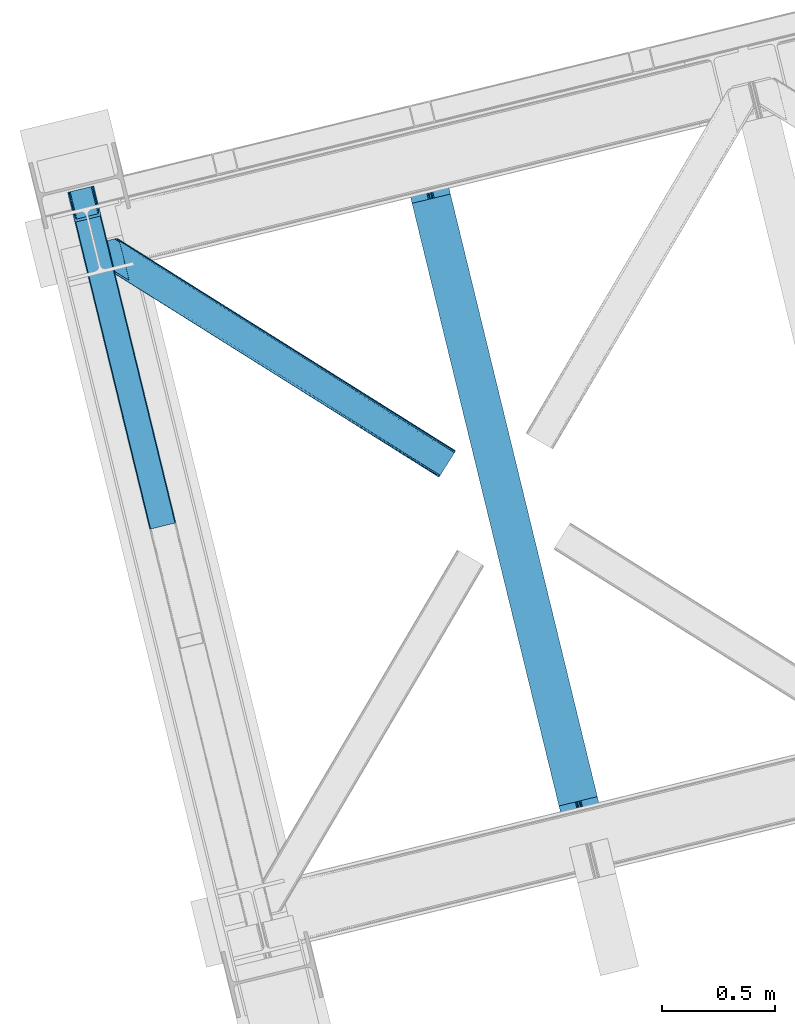
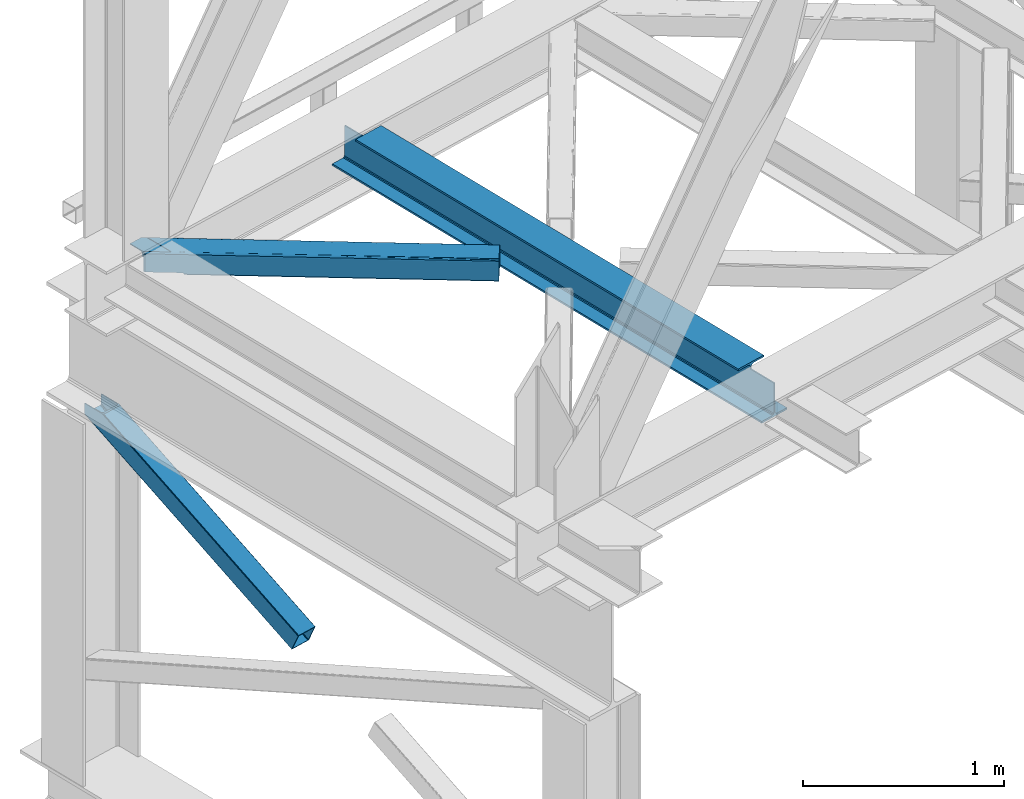
# One storey, part 25 of 92: 2 members, 1 beam.
"""IFC4 building model written with IfcOpenShell, lengths in millimetres."""

from ifc_helpers import new_model, entity, si_unit, converted_unit, derived_unit, direction, frame, origin, place, context, subcontext, project, spatial, triangles, polygons, material, type_object, element, save


model = new_model("IFC4")

# Units and contexts
model_context = context("Model", 3, precision=0.01, world=origin(), true_north=direction((6.12303176911189e-17, 1.0)))
plan_context = context("Plan", 3, precision=0.01, world=origin(), true_north=direction((6.12303176911189e-17, 1.0)))
body_context = subcontext(model_context, "Body", "Model", "MODEL_VIEW")
ifc_project = project(units=[si_unit("LENGTHUNIT", "METRE", prefix="MILLI"), si_unit("AREAUNIT", "SQUARE_METRE"), si_unit("VOLUMEUNIT", "CUBIC_METRE"), converted_unit("PLANEANGLEUNIT", "DEGREE", entity("IfcRatioMeasure", 0.0174532925199433), si_unit("PLANEANGLEUNIT", "RADIAN"), dimensions=[0, 0, 0, 0, 0, 0, 0]), si_unit("MASSUNIT", "GRAM", prefix="KILO"), derived_unit("MASSDENSITYUNIT", [(si_unit("MASSUNIT", "GRAM", prefix="KILO"), 1), (si_unit("LENGTHUNIT", "METRE"), -3)]), derived_unit("MOMENTOFINERTIAUNIT", [(si_unit("LENGTHUNIT", "METRE"), 4)]), si_unit("TIMEUNIT", "SECOND"), si_unit("FREQUENCYUNIT", "HERTZ"), si_unit("THERMODYNAMICTEMPERATUREUNIT", "DEGREE_CELSIUS"), derived_unit("THERMALTRANSMITTANCEUNIT", [(si_unit("MASSUNIT", "GRAM", prefix="KILO"), 1), (si_unit("THERMODYNAMICTEMPERATUREUNIT", "KELVIN"), -1), (si_unit("TIMEUNIT", "SECOND"), -3)]), derived_unit("VOLUMETRICFLOWRATEUNIT", [(si_unit("LENGTHUNIT", "METRE"), 3), (si_unit("TIMEUNIT", "SECOND"), -1)]), derived_unit("MASSFLOWRATEUNIT", [(si_unit("MASSUNIT", "GRAM", prefix="KILO"), 1), (si_unit("TIMEUNIT", "SECOND"), -1)]), derived_unit("ROTATIONALFREQUENCYUNIT", [(si_unit("TIMEUNIT", "SECOND"), -1)]), si_unit("ELECTRICCURRENTUNIT", "AMPERE"), si_unit("ELECTRICVOLTAGEUNIT", "VOLT"), si_unit("POWERUNIT", "WATT"), si_unit("FORCEUNIT", "NEWTON", prefix="KILO"), si_unit("ILLUMINANCEUNIT", "LUX"), si_unit("LUMINOUSFLUXUNIT", "LUMEN"), si_unit("LUMINOUSINTENSITYUNIT", "CANDELA"), derived_unit("USERDEFINED", [(si_unit("MASSUNIT", "GRAM", prefix="KILO"), -1), (si_unit("LENGTHUNIT", "METRE"), -2), (si_unit("TIMEUNIT", "SECOND"), 3), (si_unit("LUMINOUSFLUXUNIT", "LUMEN"), 1)]), derived_unit("LINEARVELOCITYUNIT", [(si_unit("LENGTHUNIT", "METRE"), 1), (si_unit("TIMEUNIT", "SECOND"), -1)]), si_unit("PRESSUREUNIT", "PASCAL"), derived_unit("USERDEFINED", [(si_unit("LENGTHUNIT", "METRE"), -2), (si_unit("MASSUNIT", "GRAM", prefix="KILO"), 1), (si_unit("TIMEUNIT", "SECOND"), -2)]), derived_unit("LINEARFORCEUNIT", [(si_unit("MASSUNIT", "GRAM", prefix="KILO"), 1), (si_unit("LENGTHUNIT", "METRE"), 1), (si_unit("TIMEUNIT", "SECOND"), -2), (si_unit("LENGTHUNIT", "METRE"), -1)]), derived_unit("PLANARFORCEUNIT", [(si_unit("MASSUNIT", "GRAM", prefix="KILO"), 1), (si_unit("LENGTHUNIT", "METRE"), 1), (si_unit("TIMEUNIT", "SECOND"), -2), (si_unit("LENGTHUNIT", "METRE"), -2)])], contexts=[model_context, plan_context])

# Site, building, storey
site_placement = place(None, origin())
site = spatial("IfcSite", under=ifc_project, at=site_placement, CompositionType="ELEMENT")
building_placement = place(site_placement, origin())
building = spatial("IfcBuilding", under=site, at=building_placement, CompositionType="ELEMENT")
storey_placement = place(building_placement, frame((0.0, 0.0, 15900.0)))
storey = spatial("IfcBuildingStorey", under=building, at=storey_placement, Name="05", CompositionType="ELEMENT", Elevation=15900.0)

# Beam
ifc_material = material(Name="Metal painted (White)")
beam_type = type_object("IfcBeamType", PredefinedType="BEAM")
beam_placement = place(storey_placement, frame((-59635.89, 3249.83, 3441.0)))
element("IfcBeam", 1, at=beam_placement, inside=storey, type_object=beam_type, material=ifc_material, ObjectType="Steel Beam", PredefinedType="BEAM", context=body_context, shape_type="Tessellation", body=[
    polygons([(900.98534618944, 41.4445662733097, 11.000000000004), (900.98534618944, 41.4445662733097, 2.16573425859679e-12), (170.021610174761, 3040.13999372697, 2.16573425859679e-12), (170.021610174761, 3040.13999372697, 11.000000000004), (834.919806235823, 25.3403919499672, 11.000000000004), (103.956070221144, 3024.03581940363, 11.000000000004), (828.971056214531, 23.8903211957396, 12.2179274798217), (98.0073201998513, 3022.5857486494, 12.2179274798217), (823.927949458422, 22.66101056892, 15.6862915010192), (92.9642134437427, 3021.35643802258, 15.6862915010192), (820.558253255246, 21.8396114687124, 20.8770650821657), (89.5945172405668, 3020.53503892237, 20.8770650821657), (819.37497330556, 21.5511744621211, 27.0000000000047), (88.4112372908809, 3020.24660191578, 27.0000000000047), (81.6103728838801, 3018.58881926485, 27.0000000000047), (81.6103728838888, 3018.58881926485, 203.000000000006), (88.4112372908809, 3020.24660191578, 203.000000000006), (0.0, 2998.69542745366, 2.16573425859679e-12), (0.0, 2998.69542745366, 10.9999999999997), (66.0655399536345, 3014.799601777, 11.000000000004), (72.014289974927, 3016.24967253123, 12.2179274798217), (77.057396731027, 3017.47898315805, 15.6862915010192), (80.4270929341942, 3018.30038225826, 20.8770650821657), (819.374973305543, 21.5511744621206, 203.000000000006), (812.574108898559, 19.8933918111892, 203.000000000006), (812.574108898559, 19.8933918111892, 27.0000000000047), (811.390828948873, 19.6049548045968, 20.8770650821657), (808.021132745698, 18.7835557043893, 15.6862915010192), (802.978025989589, 17.5542450775691, 12.2179274798217), (797.029275968296, 16.1041743233431, 11.000000000004), (730.963736014679, 0.0, 10.9999999999997), (730.963736014679, 0.0, 2.16573425859679e-12), (779.675212882757, 184.415062601692, 203.069791966819), (128.020401343512, 2857.75452019162, 203.000000000006), (128.24328213265, 2856.8401777572, 203.617301946336), (128.256196377177, 2856.7871977843, 217.000003693143), (779.530009633824, 185.010597404072, 217.000003676718), (779.530880241731, 185.007025963192, 204.00000679514), (772.964911718311, 182.385463974443, 203.006342981529), (772.742064056782, 183.299815969774, 203.617301946336), (772.729149812263, 183.352795942669, 217.000003693143), (121.455336555608, 2855.1293963229, 217.000003676718), (121.45446594771, 2855.13296776378, 204.00000679514), (121.310166358664, 2855.72494066435, 203.076120467494), (121.219536936511, 2856.09673754069, 203.000000000006), (780.713494357868, 185.298194377515, 223.122939328039), (784.082490766547, 186.122464201394, 228.313710402595), (789.125126170554, 187.353708426698, 231.782072735464), (795.073705041275, 188.80448128138, 232.999999602236), (861.13915590679, 204.909021065315, 232.999999283132), (861.137682570352, 204.915065042188, 243.999994005812), (691.116301666431, 163.469558245298, 243.999994827032), (691.117775002877, 163.463514268425, 233.000000104353), (757.183225868401, 179.568054052359, 232.999999785253), (763.132130996731, 181.017488520583, 231.782072861012), (768.175695503862, 182.244921343719, 228.313710479427), (771.546082413602, 183.063487001148, 223.12293937232), (120.271851831572, 2854.84179934945, 223.122939328039), (116.902855422893, 2854.01752952557, 228.313710402595), (111.860220018869, 2852.78628530027, 231.782072735464), (105.911641148165, 2851.33551244559, 232.999999602236), (39.8461902826505, 2835.23097266165, 232.999999283128), (39.8476636190794, 2835.22492868478, 243.999994005812), (209.869044523001, 2876.67043548167, 243.999994827032), (209.867571186572, 2876.67647945854, 233.000000104357), (143.80212032104, 2860.57193967461, 232.999999785253), (137.85321519271, 2859.12250520639, 231.782072861012), (132.809650685579, 2857.89507238325, 228.313710479427), (129.439263775838, 2857.07650672582, 223.12293937232)], [[[1, 2, 3, 4]], [[5, 1, 4, 6]], [[7, 5, 6, 8]], [[9, 7, 8, 10]], [[11, 9, 10, 12]], [[13, 11, 12, 14]], [[15, 16, 17, 14, 12, 10, 8, 6, 4, 3, 18, 19, 20, 21, 22, 23]], [[13, 24, 25, 26, 27, 28, 29, 30, 31, 32, 2, 1, 5, 7, 9, 11]], [[2, 32, 18, 3]], [[32, 31, 19, 18]], [[31, 30, 20, 19]], [[27, 26, 15, 23]], [[28, 27, 23, 22]], [[29, 28, 22, 21]], [[30, 29, 21, 20]], [[33, 24, 13, 14, 17, 34, 35, 36, 37, 38]], [[25, 39, 40, 41, 42, 43, 44, 16, 15, 26]], [[39, 25, 24, 33]], [[45, 34, 17, 16]], [[41, 40, 38, 37, 46, 47, 48, 49, 50, 51, 52, 53, 54, 55, 56, 57]], [[42, 58, 59, 60, 61, 62, 63, 64, 65, 66, 67, 68, 69, 36, 35, 43]], [[46, 37, 36, 69]], [[47, 46, 69, 68]], [[48, 47, 68, 67]], [[49, 48, 67, 66]], [[50, 49, 66, 65]], [[51, 50, 65, 64]], [[52, 51, 64, 63]], [[53, 52, 63, 62]], [[54, 53, 62, 61]], [[55, 54, 61, 60]], [[56, 55, 60, 59]], [[57, 56, 59, 58]], [[41, 57, 58, 42]]], closed=False),
])

# Members
member_type_1 = type_object("IfcMemberType", PredefinedType="BRACE")
member_1_placement = place(storey_placement, frame((-61123.58, 4641.45, 1850.35)))
element("IfcMember", 2, at=member_1_placement, inside=storey, type_object=member_type_1, ObjectType="Steel Vertical Brace", PredefinedType="BRACE", context=body_context, shape_type="Tessellation", body=[
    triangles([(109.78864746094, 1519.24680175781, 671.707836914062), (462.204345703125, 73.4905723571783, 0.0), (6.80423583984521, 1494.14368286133, 671.707836914062), (359.21993408203, 48.3871627807621, 0.0), (464.859997558597, 73.9117675781254, 0.48601684570167), (467.213342285155, 73.8434577941898, 1.86965332031104), (112.19315185547, 1519.83339385986, 672.832186889649), (468.910913085936, 73.2946540832527, 3.93929443359229), (114.59765625, 1520.41940460205, 673.956536865233), (469.687609863278, 72.3502349853516, 6.38100585937354), (115.592944335935, 1520.66183166504, 676.672650146484), (116.588232421876, 1520.90484008789, 679.387600708007), (353.104028320311, 43.9313301086431, 6.38100585937354), (0.0, 1492.48564453125, 679.387600708007), (0.99993896484375, 1492.7286529541, 676.672650146484), (353.359826660155, 45.128059387207, 3.93929443359229), (1.99522705077834, 1492.97108001709, 673.956536865233), (354.61091308594, 46.3954238891602, 1.86965332031104), (4.39973144531541, 1493.55709075928, 672.832186889649), (356.671252441403, 47.5395401000978, 0.48601684570167), (144.939990234372, 1404.59159088135, 741.646591186523), (116.588232421876, 1520.90484008789, 741.646591186523), (480.017211914063, 29.9807281494141, 102.993713378906), (28.3564086914048, 1376.17239532471, 741.646591186523), (0.0, 1492.48564453125, 741.646591186523), (363.428979492186, 1.5615325927738, 102.993713378906), (476.44998779297, 26.3725181579593, 108.888702392578), (144.465600585936, 1388.29607391357, 741.646591186523), (142.168066406251, 1386.40316619873, 741.646591186523), (473.896655273435, 25.5248954772951, 109.37471923828), (478.505676269531, 27.516634368897, 107.505065917969), (145.795751953126, 1392.41733398438, 741.646591186523), (479.761413574219, 28.7839988708502, 105.435424804688), (145.963183593747, 1398.13907775879, 741.646591186523), (39.1836547851563, 1361.29946594238, 741.646591186523), (370.912243652347, 0.421485900878906, 109.37471923828), (364.210327148438, 0.617113494873593, 105.435424804688), (30.4120971679658, 1369.97219238281, 741.646591186523), (365.90324707031, 0.0686004638673694, 107.505065917969), (33.1933227539048, 1364.96900939941, 741.646591186523), (368.256591796875, 0.0, 108.888702392578), (36.27685546875, 1361.92384643555, 741.646591186523), (138.061340332031, 1403.04052276611, 741.646591186523), (137.205578613284, 1415.21477966309, 741.646591186523), (111.728063964845, 1519.72061004639, 741.646591186523), (138.228771972659, 1408.76284790039, 741.646591186523), (136.731188964841, 1398.91926269531, 741.646591186523), (134.433654785156, 1397.02635498047, 741.646591186523), (35.1745971679702, 1377.96065826416, 741.646591186523), (32.3933715820313, 1382.96442260742, 741.646591186523), (30.333032226561, 1389.16346282959, 741.646591186523), (4.86016845703125, 1493.66987457275, 741.646591186523), (38.2534790039063, 1374.91491394043, 741.646591186523), (41.1649291992217, 1374.29111480713, 741.646591186523), (474.673352050784, 30.7952133178715, 98.4370147705085), (474.412902832031, 29.5981933593757, 100.87872619629), (473.161816406253, 28.3311195373535, 102.948367309571), (471.101477050783, 27.1867126464849, 104.330841064453), (468.552795410156, 26.3393806457525, 104.816857910155), (375.284069824222, 3.60414047241284, 104.816857910155), (372.62841796875, 3.18265457153393, 104.330841064453), (370.275073242185, 3.25154571533221, 102.948367309571), (368.577502441403, 3.79976806640661, 100.87872619629), (367.800805664061, 4.74418716430682, 98.4370147705085), (111.728063964845, 1519.72061004639, 684.873312377931), (465.315783691403, 69.1675804138185, 10.9377044677749), (4.86016845703125, 1493.66987457275, 684.873312377931), (358.447888183597, 43.1168449401857, 10.9377044677749), (462.84151611328, 70.660512542725, 6.42635192871239), (464.539086914061, 70.1122901916506, 8.49599304199364), (460.488171386722, 70.7294036865242, 5.04387817382667), (457.837170410159, 70.3079177856453, 4.557861328125), (359.954772949219, 45.5809387207037, 6.42635192871239), (362.015112304689, 46.7253456115723, 5.04387817382667), (358.70368652344, 44.3138648986824, 8.49599304199364), (364.563793945315, 47.5726776123047, 4.557861328125), (11.6597534179673, 1495.32733154297, 677.193548583986), (9.2552490234375, 1494.74132080078, 678.31789855957), (6.85074462890771, 1494.15531005859, 679.443411254884), (104.928479003909, 1518.06315307617, 677.193548583986), (107.332983398439, 1518.64916381836, 678.31789855957), (109.737487792969, 1519.23517456055, 679.443411254884), (5.85545654296584, 1493.91230163574, 682.158361816408), (110.732775878903, 1519.4781829834, 682.158361816408)], [[1, 2, 3], [4, 3, 2], [5, 2, 1], [6, 5, 7], [8, 6, 9], [10, 8, 11], [11, 12, 10], [9, 11, 8], [7, 9, 6], [1, 7, 5], [13, 14, 15], [16, 15, 17], [18, 17, 19], [20, 19, 3], [3, 4, 20], [19, 20, 18], [17, 18, 16], [15, 16, 13], [12, 21, 10], [21, 12, 22], [23, 10, 21], [24, 14, 13], [24, 25, 14], [13, 26, 24], [27, 28, 29], [29, 30, 27], [31, 32, 28], [28, 27, 31], [33, 34, 32], [32, 31, 33], [23, 21, 34], [34, 33, 23], [30, 29, 35], [35, 36, 30], [37, 38, 26], [24, 26, 38], [39, 40, 37], [38, 37, 40], [41, 42, 39], [40, 39, 42], [36, 35, 41], [42, 41, 35], [43, 34, 21], [22, 44, 21], [44, 22, 45], [44, 46, 21], [46, 43, 21], [47, 34, 43], [32, 29, 28], [32, 34, 47], [32, 48, 29], [29, 48, 35], [47, 48, 32], [24, 38, 49], [49, 50, 24], [50, 51, 24], [51, 25, 24], [52, 25, 51], [38, 53, 49], [54, 40, 35], [54, 35, 48], [54, 53, 40], [35, 40, 42], [53, 38, 40], [44, 55, 46], [56, 46, 55], [46, 56, 43], [57, 43, 56], [43, 57, 47], [58, 47, 57], [47, 58, 48], [59, 48, 58], [48, 59, 54], [60, 54, 59], [54, 60, 61], [61, 53, 54], [53, 61, 62], [62, 49, 53], [49, 62, 63], [63, 50, 49], [50, 63, 64], [64, 51, 50], [44, 65, 66], [44, 45, 65], [66, 55, 44], [67, 51, 68], [51, 67, 52], [64, 68, 51], [55, 23, 56], [57, 33, 31], [31, 27, 57], [23, 55, 10], [23, 33, 57], [57, 56, 23], [59, 30, 36], [30, 58, 57], [59, 58, 30], [30, 57, 27], [6, 69, 5], [66, 10, 55], [69, 8, 10], [70, 10, 66], [8, 69, 6], [69, 2, 5], [10, 70, 69], [69, 71, 2], [2, 72, 4], [72, 2, 71], [62, 26, 63], [36, 60, 59], [61, 36, 62], [36, 61, 60], [62, 36, 41], [64, 63, 26], [41, 39, 62], [37, 62, 39], [64, 26, 13], [37, 26, 62], [73, 20, 4], [74, 73, 4], [75, 13, 73], [76, 4, 72], [4, 76, 74], [18, 20, 73], [13, 68, 64], [16, 73, 13], [68, 13, 75], [73, 16, 18], [77, 1, 3], [3, 19, 78], [19, 17, 15], [19, 79, 78], [3, 78, 77], [79, 19, 15], [80, 1, 77], [9, 7, 11], [7, 1, 81], [81, 82, 7], [7, 82, 11], [80, 81, 1], [11, 82, 12], [83, 14, 67], [15, 14, 79], [83, 79, 14], [25, 67, 14], [25, 52, 67], [12, 84, 65], [84, 12, 82], [65, 22, 12], [22, 65, 45], [72, 80, 76], [77, 76, 80], [66, 65, 84], [70, 84, 82], [69, 82, 81], [71, 81, 80], [80, 72, 71], [81, 71, 69], [82, 69, 70], [84, 70, 66], [74, 76, 77], [73, 74, 78], [75, 73, 79], [68, 75, 83], [83, 67, 68], [79, 83, 75], [78, 79, 73], [77, 78, 74]]),
])
member_type_2 = type_object("IfcMemberType", PredefinedType="BRACE")
member_2_placement = place(storey_placement, frame((-60991.5, 4870.09, 3511.0)))
element("IfcMember", 3, at=member_2_placement, inside=storey, type_object=member_type_2, ObjectType="Steel Horizontal Brace", PredefinedType="BRACE", context=body_context, shape_type="Tessellation", body=[
    triangles([(207.717553710936, 841.06494140625, 0.0), (172.040661621089, 987.427519226074, 0.0), (1579.91751708985, 103.755294799805, 0.0), (1524.09766845703, 14.8223510742182, 0.0), (1589.22392578125, 118.577645874023, 17.5000946044929), (1588.51234130859, 117.449226379395, 10.8028289794929), (166.547973632813, 1009.96451568604, 10.8028289794929), (166.092187499999, 1011.82137908936, 17.5000946044929), (1586.49851074219, 114.236631774902, 5.12526855468968), (167.836267089842, 1004.67646636963, 5.12526855468968), (1583.48009033203, 109.42762298584, 1.33247680664135), (169.766381835936, 996.762414550781, 1.33247680664135), (1520.53974609375, 9.15002288818323, 1.33247680664135), (202.587634277341, 836.379180908203, 1.33247680664135), (208.508203124999, 837.822697448731, 0.155804443362285), (1517.52132568359, 4.34130477905273, 5.12526855468968), (194.895080566406, 834.504295349121, 5.12526855468968), (1515.50284423828, 1.12841949462836, 10.8028289794929), (189.755859375, 833.25146484375, 10.8028289794929), (1514.79591064453, 0.0, 17.5000946044929), (187.951318359374, 832.811375427246, 17.5000946044929), (204.378222656247, 836.815782165527, 12.1260040283232), (208.508203124999, 837.822697448731, 9.69243164062573), (199.648278808592, 835.663526916504, 17.9802978515654), (198.420446777345, 835.364126586914, 19.4999725341804), (187.951318359374, 832.811375427246, 19.4999725341804), (25.3054321289019, 934.895260620117, 19.4999725341804), (22.6823364257798, 945.669602966308, 19.4999725341804), (1514.79591064453, 0.0, 122.500662231447), (25.3054321289019, 934.895260620117, 122.500662231447), (1527.81837158203, 20.7510589599606, 6.99957275390625), (205.340954589839, 850.822485351562, 6.99957275390625), (207.559423828126, 841.724784851074, 8.88434143066479), (1524.26044921875, 15.0787307739256, 8.3320495605476), (1521.24202880859, 10.270303344726, 12.1260040283232), (1519.22354736328, 7.05712738037073, 17.8035644531265), (1518.51661376953, 5.92899856567328, 24.4996673583992), (22.9288330078125, 944.65280456543, 24.4996673583992), (174.417260742186, 977.669975280762, 6.99957275390625), (1576.19681396485, 97.8265869140623, 6.99957275390625), (168.966430664063, 1000.03372650147, 17.8803039550803), (170.212866210939, 994.918922424316, 12.1260040283232), (172.142980957033, 987.004870605469, 8.3320495605476), (168.831555175777, 1000.58543701172, 18.5000335693367), (166.092187499999, 1011.82137908936, 18.5000335693367), (1518.51661376953, 5.92899856567328, 115.501089477541), (22.9288330078125, 944.65280456543, 115.501089477541), (1527.81837158203, 20.7510589599606, 133.000021362306), (1524.26044921875, 15.0787307739256, 131.667544555665), (19.2592895507769, 959.711769104004, 131.667544555665), (16.9803588867144, 969.046664428711, 133.000021362306), (1521.24202880859, 10.270303344726, 127.87475280762), (21.1894042968706, 951.797717285156, 127.87475280762), (1519.22354736328, 7.05712738037073, 122.196029663086), (22.4776977539077, 946.509667968749, 122.196029663086), (168.515295410158, 1000.87960510254, 18.7407165527366), (165.808483886714, 1012.00160064697, 18.736065673831), (168.171130371091, 1001.19760894775, 19.0000030517585), (165.487573242186, 1012.20275115967, 19.0000030517585), (167.826965332031, 1001.51561279297, 19.2592895507842), (165.166662597658, 1012.4033203125, 19.2639404296897), (167.506054687496, 1001.80978088379, 19.4999725341804), (164.878308105464, 1012.58412322998, 19.4999725341804), (78.2928955078096, 1057.80520019531, 19.4999725341804), (88.7666748046831, 1060.35795135498, 19.4999725341804), (24.8542968749971, 936.752124023437, 129.197927856447), (23.5660034179673, 942.040173339844, 134.874325561526), (22.1195800781206, 947.964811706543, 137.999716186525), (0.0, 1038.72031860352, 137.999716186525), (0.0, 1038.72031860352, 133.000021362306), (1589.22392578125, 118.577645874023, 122.500662231447), (88.7666748046831, 1060.35795135498, 122.500662231447), (1584.79163818359, 111.520518493652, 17.8035644531265), (1585.50322265625, 112.648937988281, 24.4996673583992), (79.2788818359331, 1058.04588317871, 24.4996673583992), (1579.75938720703, 103.498915100097, 8.3320495605476), (1582.77780761719, 108.307342529297, 12.1260040283232), (64.6425659179658, 1054.47807769775, 131.667544555665), (55.5687011718765, 1052.26658477783, 133.000021362306), (76.0604736328096, 1057.26162872314, 137.999716186525), (81.8229125976577, 1058.66503143311, 134.874325561526), (72.3351196289077, 1056.3535446167, 127.87475280762), (77.474340820314, 1057.60637512207, 122.196029663086), (86.962133789064, 1059.91786193848, 129.197927856447), (79.2788818359331, 1058.04588317871, 115.501089477541), (1576.19681396485, 97.8265869140623, 133.000021362306), (1585.50322265625, 112.648937988281, 115.501089477541), (1584.79163818359, 111.520518493652, 122.196029663086), (1582.77780761719, 108.307342529297, 127.87475280762), (1579.75938720703, 103.498915100097, 131.667544555665), (1588.51234130859, 117.449226379395, 129.197927856447), (1586.49851074219, 114.236631774902, 134.874325561526), (1583.48009033203, 109.42762298584, 138.667117309571), (1579.91751708985, 103.755294799805, 139.999594116212), (1524.09766845703, 14.8223510742182, 139.999594116212), (1520.53974609375, 9.15002288818323, 138.667117309571), (1517.52132568359, 4.34130477905273, 134.874325561526), (1515.50284423828, 1.12841949462836, 129.197927856447), (98.1893554687485, 1043.37177886963, 137.999716186525), (139.386840820313, 874.360583496094, 137.999716186525), (137.842749023439, 884.922148132324, 139.999594116212), (139.824023437497, 876.794155883789, 138.999655151369), (140.051916503908, 875.630273437499, 138.667117309571), (139.805419921875, 874.273379516601, 138.076455688479), (139.917041015622, 874.907643127442, 138.353182983399), (98.7056030273452, 1042.87529754639, 138.076455688479), (99.5985717773438, 1040.78647155762, 138.634561157229), (99.1985961914033, 1041.72362365723, 138.383413696291), (100.184582519527, 1039.41271820068, 138.999655151369), (102.165856933592, 1031.28472595215, 139.999594116212), (140.033312988278, 875.544232177735, 138.629910278323)], [[1, 2, 3], [3, 4, 1], [5, 6, 7], [7, 8, 5], [6, 9, 10], [10, 7, 6], [9, 11, 12], [12, 10, 9], [11, 3, 2], [2, 12, 11], [13, 14, 15], [15, 4, 13], [15, 1, 4], [13, 16, 14], [17, 14, 16], [16, 18, 17], [19, 17, 18], [18, 20, 19], [21, 19, 20], [22, 23, 14], [22, 14, 17], [17, 19, 24], [23, 15, 14], [24, 22, 17], [19, 21, 25], [26, 25, 21], [19, 25, 24], [27, 28, 25], [25, 26, 27], [26, 29, 30], [20, 26, 21], [26, 20, 29], [26, 30, 27], [31, 32, 33], [34, 33, 23], [23, 35, 34], [23, 22, 35], [36, 35, 22], [37, 36, 24], [24, 25, 37], [37, 25, 38], [28, 38, 25], [22, 24, 36], [33, 34, 31], [39, 32, 40], [31, 40, 32], [41, 7, 10], [10, 42, 41], [12, 42, 10], [42, 12, 43], [7, 44, 8], [45, 8, 44], [7, 41, 44], [43, 12, 2], [33, 32, 1], [1, 39, 2], [39, 1, 32], [15, 33, 1], [39, 43, 2], [23, 33, 15], [46, 37, 38], [38, 47, 46], [48, 49, 50], [50, 51, 48], [49, 52, 53], [53, 50, 49], [52, 54, 55], [55, 53, 52], [54, 46, 47], [47, 55, 54], [45, 44, 56], [56, 57, 45], [57, 56, 58], [58, 59, 57], [59, 58, 60], [60, 61, 59], [61, 60, 62], [62, 63, 61], [64, 65, 63], [63, 62, 64], [47, 27, 30], [66, 55, 30], [55, 66, 67], [55, 47, 30], [38, 27, 47], [28, 27, 38], [53, 55, 67], [68, 51, 50], [51, 68, 69], [69, 70, 51], [50, 53, 68], [68, 53, 67], [5, 45, 71], [8, 45, 5], [45, 72, 71], [72, 45, 57], [72, 57, 59], [59, 61, 72], [63, 72, 61], [72, 63, 65], [73, 41, 42], [74, 75, 62], [62, 73, 74], [56, 73, 58], [56, 44, 73], [73, 60, 58], [73, 62, 60], [44, 41, 73], [75, 64, 62], [40, 76, 39], [43, 39, 76], [76, 77, 43], [42, 43, 77], [42, 77, 73], [78, 79, 80], [81, 82, 80], [78, 80, 82], [83, 81, 84], [79, 69, 80], [79, 70, 69], [83, 82, 81], [72, 85, 83], [85, 72, 65], [75, 65, 64], [65, 75, 85], [72, 83, 84], [51, 79, 86], [79, 51, 70], [86, 48, 51], [74, 87, 75], [85, 75, 87], [87, 88, 85], [83, 85, 88], [88, 89, 83], [82, 83, 89], [89, 90, 82], [78, 82, 90], [90, 86, 78], [79, 78, 86], [91, 89, 88], [87, 5, 71], [91, 88, 71], [91, 92, 89], [88, 87, 71], [89, 92, 93], [86, 94, 95], [94, 90, 93], [90, 94, 86], [90, 89, 93], [6, 77, 9], [74, 5, 87], [5, 73, 6], [73, 5, 74], [6, 73, 77], [3, 40, 4], [11, 9, 77], [77, 76, 11], [76, 40, 3], [3, 11, 76], [52, 96, 97], [95, 48, 86], [95, 49, 48], [49, 95, 96], [52, 49, 96], [46, 29, 20], [98, 54, 52], [97, 98, 52], [54, 98, 29], [46, 54, 29], [13, 35, 16], [4, 40, 31], [31, 34, 4], [34, 35, 13], [13, 4, 34], [18, 16, 35], [20, 37, 46], [36, 20, 18], [20, 36, 37], [36, 18, 35], [80, 68, 99], [80, 69, 68], [100, 99, 68], [95, 101, 102], [102, 96, 95], [102, 103, 96], [97, 104, 100], [100, 67, 97], [100, 68, 67], [96, 105, 104], [96, 103, 105], [104, 97, 96], [29, 98, 30], [66, 30, 98], [98, 97, 66], [67, 66, 97], [92, 81, 106], [106, 93, 92], [107, 93, 108], [106, 108, 93], [81, 80, 99], [107, 94, 93], [107, 109, 94], [109, 110, 94], [92, 91, 84], [84, 81, 92], [91, 71, 72], [72, 84, 91], [110, 101, 94], [95, 94, 101], [111, 102, 109], [109, 107, 111], [107, 108, 104], [108, 106, 104], [110, 109, 101], [102, 101, 109]]),
])

save(model, "model.ifc")
